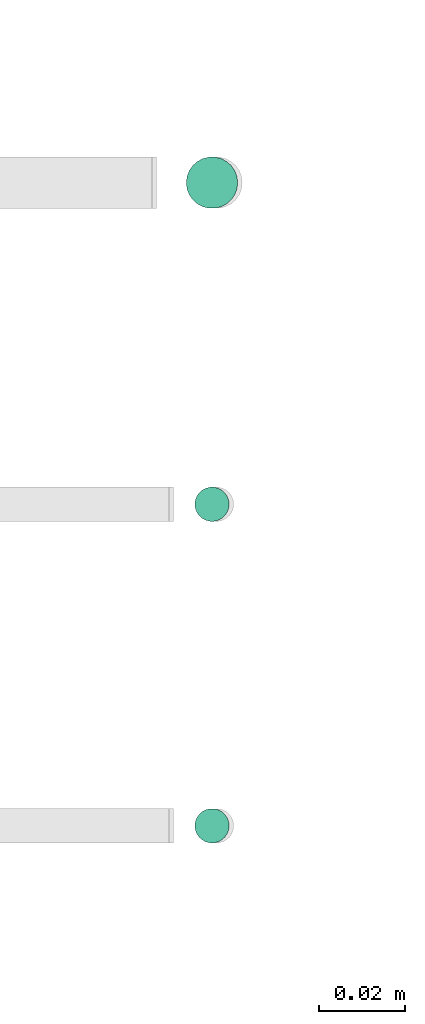
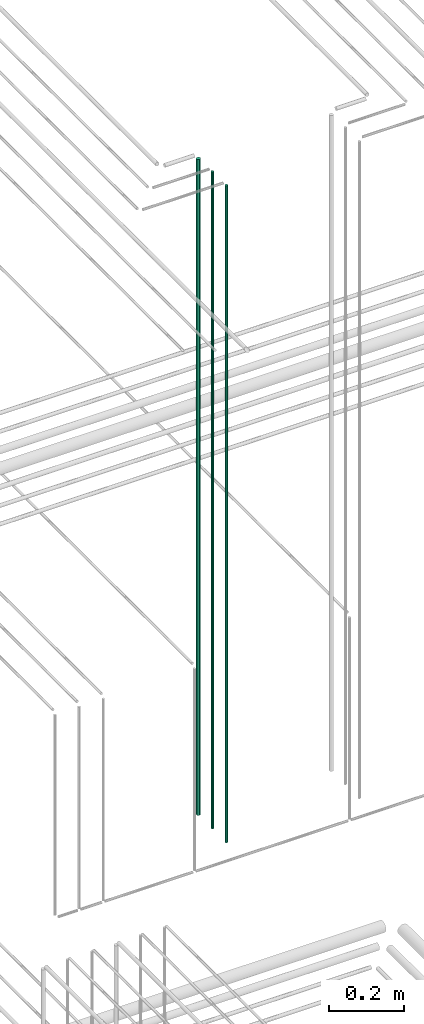
# One storey, part 58 of 331: 3 flow segments.
"""IFC2X3 building model written with IfcOpenShell, lengths in millimetres."""

from ifc_helpers import new_model, entity, si_unit, converted_unit, derived_unit, direction, frame, frame_2d, origin, origin_2d_with_axis, place, context, subcontext, project, spatial, circle, extrude, type_object, element, save


model = new_model("IFC2X3")

# Units and contexts
model_context = context("Model", 3, precision=0.01, world=origin(), true_north=direction((6.12303176911189e-17, 1.0)))
body_context = subcontext(model_context, "Body", "Model", "MODEL_VIEW")
ifc_project = project(units=[si_unit("LENGTHUNIT", "METRE", prefix="MILLI"), si_unit("AREAUNIT", "SQUARE_METRE"), si_unit("VOLUMEUNIT", "CUBIC_METRE"), converted_unit("PLANEANGLEUNIT", "DEGREE", entity("IfcRatioMeasure", 0.0174532925199433), si_unit("PLANEANGLEUNIT", "RADIAN"), dimensions=[0, 0, 0, 0, 0, 0, 0]), si_unit("MASSUNIT", "GRAM", prefix="KILO"), derived_unit("MASSDENSITYUNIT", [(si_unit("MASSUNIT", "GRAM", prefix="KILO"), 1), (si_unit("LENGTHUNIT", "METRE"), -3)]), derived_unit("MOMENTOFINERTIAUNIT", [(si_unit("LENGTHUNIT", "METRE"), 4)]), si_unit("TIMEUNIT", "SECOND"), si_unit("FREQUENCYUNIT", "HERTZ"), si_unit("THERMODYNAMICTEMPERATUREUNIT", "DEGREE_CELSIUS"), derived_unit("THERMALTRANSMITTANCEUNIT", [(si_unit("MASSUNIT", "GRAM", prefix="KILO"), 1), (si_unit("THERMODYNAMICTEMPERATUREUNIT", "KELVIN"), -1), (si_unit("TIMEUNIT", "SECOND"), -3)]), derived_unit("VOLUMETRICFLOWRATEUNIT", [(si_unit("LENGTHUNIT", "METRE"), 3), (si_unit("TIMEUNIT", "SECOND"), -1)]), derived_unit("MASSFLOWRATEUNIT", [(si_unit("MASSUNIT", "GRAM", prefix="KILO"), 1), (si_unit("TIMEUNIT", "SECOND"), -1)]), derived_unit("ROTATIONALFREQUENCYUNIT", [(si_unit("TIMEUNIT", "SECOND"), -1)]), si_unit("ELECTRICCURRENTUNIT", "AMPERE"), si_unit("ELECTRICVOLTAGEUNIT", "VOLT"), si_unit("POWERUNIT", "WATT"), si_unit("FORCEUNIT", "NEWTON", prefix="KILO"), si_unit("ILLUMINANCEUNIT", "LUX"), si_unit("LUMINOUSFLUXUNIT", "LUMEN"), si_unit("LUMINOUSINTENSITYUNIT", "CANDELA"), derived_unit("USERDEFINED", [(si_unit("MASSUNIT", "GRAM", prefix="KILO"), -1), (si_unit("LENGTHUNIT", "METRE"), -2), (si_unit("TIMEUNIT", "SECOND"), 3), (si_unit("LUMINOUSFLUXUNIT", "LUMEN"), 1)]), derived_unit("LINEARVELOCITYUNIT", [(si_unit("LENGTHUNIT", "METRE"), 1), (si_unit("TIMEUNIT", "SECOND"), -1)]), si_unit("PRESSUREUNIT", "PASCAL"), derived_unit("USERDEFINED", [(si_unit("LENGTHUNIT", "METRE"), -2), (si_unit("MASSUNIT", "GRAM", prefix="KILO"), 1), (si_unit("TIMEUNIT", "SECOND"), -2)]), derived_unit("LINEARFORCEUNIT", [(si_unit("MASSUNIT", "GRAM", prefix="KILO"), 1), (si_unit("LENGTHUNIT", "METRE"), 1), (si_unit("TIMEUNIT", "SECOND"), -2), (si_unit("LENGTHUNIT", "METRE"), -1)]), derived_unit("PLANARFORCEUNIT", [(si_unit("MASSUNIT", "GRAM", prefix="KILO"), 1), (si_unit("LENGTHUNIT", "METRE"), 1), (si_unit("TIMEUNIT", "SECOND"), -2), (si_unit("LENGTHUNIT", "METRE"), -2)])], contexts=[model_context])

# Site, building, storey
site_placement = place(None, frame((0.0, -0.00077364408347762, 0.0)))
site = spatial("IfcSite", under=ifc_project, at=site_placement, CompositionType="ELEMENT")
building_placement = place(site_placement, origin())
building = spatial("IfcBuilding", under=site, at=building_placement, CompositionType="ELEMENT")
storey_placement = place(building_placement, origin())
storey = spatial("IfcBuildingStorey", under=building, at=storey_placement, CompositionType="ELEMENT", Elevation=0.0)

# Flow segments
pipe_segment_type = type_object("IfcPipeSegmentType", PredefinedType="NOTDEFINED")
flow_segment_placement = place(storey_placement, frame((53156.8310109464, 3883.89349484376, 16890.0)))
element("IfcFlowSegment", 1, at=flow_segment_placement, inside=storey, type_object=pipe_segment_type, context=body_context, shape_type="SweptSolid", body=[
    extrude(circle(Radius=6.0, at=frame_2d((0.0, 5.41433564649196e-13), x_axis=(1.0, 0.0))), frame((7.59527223591454, 7.59527223591562, 0.0)), (0.0, 0.0, 1.0), 2146.0),
])
for number, where in (
    (2, (53158.8310109464, 3735.89349484376, 16890.0)),
    (3, (53158.8310109464, 3810.89349484376, 16890.0)),
):
    element("IfcFlowSegment", number, at=place(storey_placement, frame(where)), inside=storey, type_object=pipe_segment_type, context=body_context, shape_type="SweptSolid", body=[
        extrude(circle(Radius=4.0, at=origin_2d_with_axis()), frame((5.59527223591499, 5.59527223591607, 0.0)), (0.0, 0.0, 1.0), 2150.00000000001),
    ])

save(model, "model.ifc")
